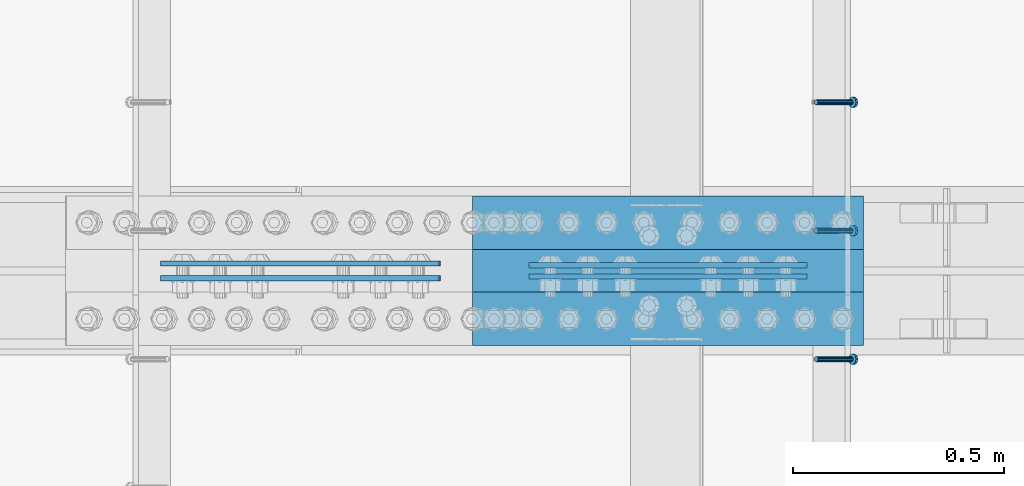
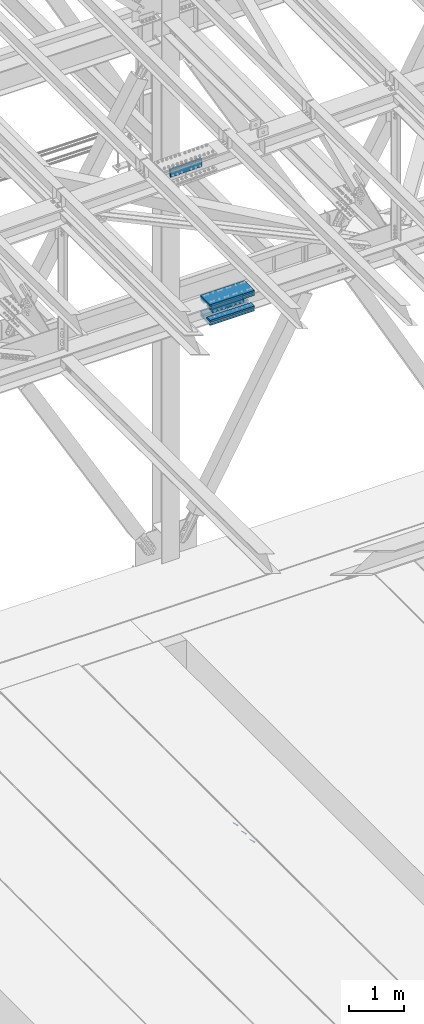
# One storey, part 2485 of 3843: 10 beams, 3 members, 4 elements without a shape of their own.
"""IFC2X3 building model written with IfcOpenShell, lengths in millimetres."""

from ifc_helpers import new_model, si_unit, frame, origin_with_axes, place, context, subcontext, project, spatial, faceted_brep, material, type_object, element, aggregate, save


model = new_model("IFC2X3")

# Units and contexts
model_context = context("Model", 3, precision=1e-05, world=origin_with_axes())
body_context = subcontext(model_context, "Body", "Model", "MODEL_VIEW")
ifc_project = project(units=[si_unit("LENGTHUNIT", "METRE", prefix="MILLI"), si_unit("AREAUNIT", "SQUARE_METRE"), si_unit("VOLUMEUNIT", "CUBIC_METRE"), si_unit("MASSUNIT", "GRAM", prefix="KILO"), si_unit("TIMEUNIT", "SECOND"), si_unit("PLANEANGLEUNIT", "RADIAN"), si_unit("SOLIDANGLEUNIT", "STERADIAN"), si_unit("THERMODYNAMICTEMPERATUREUNIT", "DEGREE_CELSIUS"), si_unit("LUMINOUSINTENSITYUNIT", "LUMEN")], contexts=[model_context])

# Site, building, storey
site_placement = place(None, origin_with_axes())
site = spatial("IfcSite", under=ifc_project, at=site_placement, CompositionType="ELEMENT")
building_placement = place(site_placement, origin_with_axes())
building = spatial("IfcBuilding", under=site, at=building_placement, Name="Undefined", CompositionType="ELEMENT")
storey_placement = place(building_placement, origin_with_axes())
storey = spatial("IfcBuildingStorey", under=building, at=storey_placement, Name="Undefined", CompositionType="ELEMENT", Elevation=0.0)

# Assembly, member
assembly_1_placement = place(storey_placement, origin_with_axes())
assembly_1 = element("IfcElementAssembly", 1, at=assembly_1_placement, inside=storey, Name="EMBED_ANGLE", AssemblyPlace="NOTDEFINED", PredefinedType="RIGID_FRAME")
ifc_material_1 = material(Name="STEEL/A108")
member_type = type_object("IfcMemberType", PredefinedType="NOTDEFINED")
member_1_placement = place(assembly_1_placement, frame((52815.2995, 83775.4227092285, 30446.6625), z_axis=(0.0, 1.0, 0.0), x_axis=(0.707106781186548, 0.0, -0.707106781186548)))
member_1 = element("IfcMember", 2, at=member_1_placement, type_object=member_type, material=ifc_material_1, Name="HEADED STUD ANCHOR", context=body_context, shape_type="Brep", body=[
    faceted_brep([(7.27595761418343e-12, -3.18000006675175, 5.5), (0.0, -5.49999999998363, 3.1800000667572), (118.110000000976, -5.49999999999091, 3.1800000667572), (118.110000000983, -3.18000006675175, 5.5), (0.0, -6.3499999046162, 0.0), (118.110000000968, -6.34999990461256, 0.0), (0.0, -5.49999999998363, -3.1800000667572), (118.110000000976, -5.49999999999091, -3.1800000667572), (7.27595761418343e-12, -3.18000006675175, -5.5), (118.110000000983, -3.18000006675175, -5.5), (7.27595761418343e-12, -1.81898940354586e-12, -6.34999990463257), (118.110000000968, -1.81898940354586e-12, -6.34999990463257), (0.0, 3.18000006675175, -5.5), (118.110000000968, 3.18000006674811, -5.5), (7.27595761418343e-12, 5.49999999998363, -3.1800000667572), (118.110000000983, 5.49999999998363, -3.1800000667572), (7.27595761418343e-12, 6.3499999046162, 0.0), (118.110000000976, 6.34999990461256, 0.0), (7.27595761418343e-12, 5.49999999998363, 3.1800000667572), (118.110000000983, 5.49999999998363, 3.1800000667572), (0.0, 3.18000006675175, 5.5), (118.110000000968, 3.18000006674811, 5.5), (7.27595761418343e-12, -1.81898940354586e-12, 6.34999990463257), (118.110000000968, -1.81898940354586e-12, 6.34999990463257), (120.650000000991, -10.9899997710909, 6.34999990463257), (120.650000000998, -6.34000015257152, 10.9899997711182), (120.650000000991, -12.6999998092379, 0.0), (120.650000000991, -10.9899997710909, -6.34999990463257), (120.650000000998, -6.34000015257152, -10.9899997711182), (120.650000000991, -1.81898940354586e-12, -12.6899995803833), (120.650000000991, 6.34000015257152, -10.9899997711182), (120.650000000998, 10.9899997710909, -6.34999990463257), (120.650000000991, 12.6999998092342, 0.0), (120.650000000998, 10.9899997710909, 6.34999990463257), (120.650000000991, 6.34000015257152, 10.9899997711182), (120.650000000991, -1.81898940354586e-12, 12.6899995803833), (127.000000001048, -10.9899997710945, 6.34999990463257), (127.000000001048, -6.34000015257152, 10.9899997711182), (127.000000001048, -12.6999998092342, 0.0), (127.000000001048, -10.9899997710945, -6.34999990463257), (127.000000001048, -6.34000015257152, -10.9899997711182), (127.000000001048, 1.81898940354586e-12, -12.6899995803833), (127.000000001048, 6.34000015256788, -10.9899997711182), (127.000000001048, 10.9899997710909, -6.34999990463257), (127.000000001048, 12.6999998092379, 0.0), (127.000000001048, 10.9899997710909, 6.34999990463257), (127.000000001048, 6.34000015256788, 10.9899997711182), (127.000000001048, 1.81898940354586e-12, 12.6899995803833)], [[[0, 1, 2, 3]], [[1, 4, 5, 2]], [[4, 6, 7, 5]], [[6, 8, 9, 7]], [[8, 10, 11, 9]], [[10, 12, 13, 11]], [[12, 14, 15, 13]], [[14, 16, 17, 15]], [[16, 18, 19, 17]], [[18, 20, 21, 19]], [[20, 22, 23, 21]], [[22, 0, 3, 23]], [[22, 20, 18, 16, 14, 12, 10, 8, 6, 4, 1, 0]], [[3, 2, 24, 25]], [[2, 5, 26, 24]], [[5, 7, 27, 26]], [[7, 9, 28, 27]], [[9, 11, 29, 28]], [[11, 13, 30, 29]], [[13, 15, 31, 30]], [[15, 17, 32, 31]], [[17, 19, 33, 32]], [[19, 21, 34, 33]], [[21, 23, 35, 34]], [[23, 3, 25, 35]], [[25, 24, 36, 37]], [[24, 26, 38, 36]], [[26, 27, 39, 38]], [[27, 28, 40, 39]], [[28, 29, 41, 40]], [[29, 30, 42, 41]], [[30, 31, 43, 42]], [[31, 32, 44, 43]], [[32, 33, 45, 44]], [[33, 34, 46, 45]], [[34, 35, 47, 46]], [[35, 25, 37, 47]], [[38, 39, 40, 41, 42, 43, 44, 45, 46, 47, 37, 36]]]),
])
aggregate(assembly_1, [member_1])

# Assembly, members
assembly_2_placement = place(storey_placement, origin_with_axes())
assembly_2 = element("IfcElementAssembly", 3, at=assembly_2_placement, inside=storey, Name="EMBED_ANGLE", AssemblyPlace="NOTDEFINED", PredefinedType="RIGID_FRAME")
member_2_placement = place(assembly_2_placement, frame((52815.2995, 84080.2227092285, 30446.6625), z_axis=(0.0, 1.0, 0.0), x_axis=(0.707106781186548, 0.0, -0.707106781186548)))
member_2 = element("IfcMember", 4, at=member_2_placement, type_object=member_type, material=ifc_material_1, Name="HEADED STUD ANCHOR", context=body_context, shape_type="Brep", body=[
    faceted_brep([(7.27595761418343e-12, -3.18000006675175, 5.5), (0.0, -5.49999999998363, 3.1800000667572), (118.110000000976, -5.49999999999091, 3.1800000667572), (118.110000000983, -3.18000006675175, 5.5), (0.0, -6.3499999046162, 0.0), (118.110000000968, -6.34999990461256, 0.0), (0.0, -5.49999999998363, -3.1800000667572), (118.110000000976, -5.49999999999091, -3.1800000667572), (7.27595761418343e-12, -3.18000006675175, -5.5), (118.110000000983, -3.18000006675175, -5.5), (7.27595761418343e-12, -1.81898940354586e-12, -6.34999990463257), (118.110000000968, -1.81898940354586e-12, -6.34999990463257), (0.0, 3.18000006675175, -5.5), (118.110000000968, 3.18000006674811, -5.5), (7.27595761418343e-12, 5.49999999998363, -3.1800000667572), (118.110000000983, 5.49999999998363, -3.1800000667572), (7.27595761418343e-12, 6.3499999046162, 0.0), (118.110000000976, 6.34999990461256, 0.0), (7.27595761418343e-12, 5.49999999998363, 3.1800000667572), (118.110000000983, 5.49999999998363, 3.1800000667572), (0.0, 3.18000006675175, 5.5), (118.110000000968, 3.18000006674811, 5.5), (7.27595761418343e-12, -1.81898940354586e-12, 6.34999990463257), (118.110000000968, -1.81898940354586e-12, 6.34999990463257), (120.650000000991, -10.9899997710909, 6.34999990463257), (120.650000000998, -6.34000015257152, 10.9899997711182), (120.650000000991, -12.6999998092379, 0.0), (120.650000000991, -10.9899997710909, -6.34999990463257), (120.650000000998, -6.34000015257152, -10.9899997711182), (120.650000000991, -1.81898940354586e-12, -12.6899995803833), (120.650000000991, 6.34000015257152, -10.9899997711182), (120.650000000998, 10.9899997710909, -6.34999990463257), (120.650000000991, 12.6999998092342, 0.0), (120.650000000998, 10.9899997710909, 6.34999990463257), (120.650000000991, 6.34000015257152, 10.9899997711182), (120.650000000991, -1.81898940354586e-12, 12.6899995803833), (127.000000001048, -10.9899997710945, 6.34999990463257), (127.000000001048, -6.34000015257152, 10.9899997711182), (127.000000001048, -12.6999998092342, 0.0), (127.000000001048, -10.9899997710945, -6.34999990463257), (127.000000001048, -6.34000015257152, -10.9899997711182), (127.000000001048, 1.81898940354586e-12, -12.6899995803833), (127.000000001048, 6.34000015256788, -10.9899997711182), (127.000000001048, 10.9899997710909, -6.34999990463257), (127.000000001048, 12.6999998092379, 0.0), (127.000000001048, 10.9899997710909, 6.34999990463257), (127.000000001048, 6.34000015256788, 10.9899997711182), (127.000000001048, 1.81898940354586e-12, 12.6899995803833)], [[[0, 1, 2, 3]], [[1, 4, 5, 2]], [[4, 6, 7, 5]], [[6, 8, 9, 7]], [[8, 10, 11, 9]], [[10, 12, 13, 11]], [[12, 14, 15, 13]], [[14, 16, 17, 15]], [[16, 18, 19, 17]], [[18, 20, 21, 19]], [[20, 22, 23, 21]], [[22, 0, 3, 23]], [[22, 20, 18, 16, 14, 12, 10, 8, 6, 4, 1, 0]], [[3, 2, 24, 25]], [[2, 5, 26, 24]], [[5, 7, 27, 26]], [[7, 9, 28, 27]], [[9, 11, 29, 28]], [[11, 13, 30, 29]], [[13, 15, 31, 30]], [[15, 17, 32, 31]], [[17, 19, 33, 32]], [[19, 21, 34, 33]], [[21, 23, 35, 34]], [[23, 3, 25, 35]], [[25, 24, 36, 37]], [[24, 26, 38, 36]], [[26, 27, 39, 38]], [[27, 28, 40, 39]], [[28, 29, 41, 40]], [[29, 30, 42, 41]], [[30, 31, 43, 42]], [[31, 32, 44, 43]], [[32, 33, 45, 44]], [[33, 34, 46, 45]], [[34, 35, 47, 46]], [[35, 25, 37, 47]], [[38, 39, 40, 41, 42, 43, 44, 45, 46, 47, 37, 36]]]),
])
member_3_placement = place(assembly_2_placement, frame((52815.2995, 84385.0227092285, 30446.6625), z_axis=(0.0, 1.0, 0.0), x_axis=(0.707106781186548, 0.0, -0.707106781186548)))
member_3 = element("IfcMember", 5, at=member_3_placement, type_object=member_type, material=ifc_material_1, Name="HEADED STUD ANCHOR", context=body_context, shape_type="Brep", body=[
    faceted_brep([(7.27595761418343e-12, -3.18000006675175, 5.5), (0.0, -5.49999999998363, 3.1800000667572), (118.110000000976, -5.49999999999091, 3.1800000667572), (118.110000000983, -3.18000006675175, 5.5), (0.0, -6.3499999046162, 0.0), (118.110000000968, -6.34999990461256, 0.0), (0.0, -5.49999999998363, -3.1800000667572), (118.110000000976, -5.49999999999091, -3.1800000667572), (7.27595761418343e-12, -3.18000006675175, -5.5), (118.110000000983, -3.18000006675175, -5.5), (7.27595761418343e-12, -1.81898940354586e-12, -6.34999990463257), (118.110000000968, -1.81898940354586e-12, -6.34999990463257), (0.0, 3.18000006675175, -5.5), (118.110000000968, 3.18000006674811, -5.5), (7.27595761418343e-12, 5.49999999998363, -3.1800000667572), (118.110000000983, 5.49999999998363, -3.1800000667572), (7.27595761418343e-12, 6.3499999046162, 0.0), (118.110000000976, 6.34999990461256, 0.0), (7.27595761418343e-12, 5.49999999998363, 3.1800000667572), (118.110000000983, 5.49999999998363, 3.1800000667572), (0.0, 3.18000006675175, 5.5), (118.110000000968, 3.18000006674811, 5.5), (7.27595761418343e-12, -1.81898940354586e-12, 6.34999990463257), (118.110000000968, -1.81898940354586e-12, 6.34999990463257), (120.650000000991, -10.9899997710909, 6.34999990463257), (120.650000000998, -6.34000015257152, 10.9899997711182), (120.650000000991, -12.6999998092379, 0.0), (120.650000000991, -10.9899997710909, -6.34999990463257), (120.650000000998, -6.34000015257152, -10.9899997711182), (120.650000000991, -1.81898940354586e-12, -12.6899995803833), (120.650000000991, 6.34000015257152, -10.9899997711182), (120.650000000998, 10.9899997710909, -6.34999990463257), (120.650000000991, 12.6999998092342, 0.0), (120.650000000998, 10.9899997710909, 6.34999990463257), (120.650000000991, 6.34000015257152, 10.9899997711182), (120.650000000991, -1.81898940354586e-12, 12.6899995803833), (127.000000001048, -10.9899997710945, 6.34999990463257), (127.000000001048, -6.34000015257152, 10.9899997711182), (127.000000001048, -12.6999998092342, 0.0), (127.000000001048, -10.9899997710945, -6.34999990463257), (127.000000001048, -6.34000015257152, -10.9899997711182), (127.000000001048, 1.81898940354586e-12, -12.6899995803833), (127.000000001048, 6.34000015256788, -10.9899997711182), (127.000000001048, 10.9899997710909, -6.34999990463257), (127.000000001048, 12.6999998092379, 0.0), (127.000000001048, 10.9899997710909, 6.34999990463257), (127.000000001048, 6.34000015256788, 10.9899997711182), (127.000000001048, 1.81898940354586e-12, 12.6899995803833)], [[[0, 1, 2, 3]], [[1, 4, 5, 2]], [[4, 6, 7, 5]], [[6, 8, 9, 7]], [[8, 10, 11, 9]], [[10, 12, 13, 11]], [[12, 14, 15, 13]], [[14, 16, 17, 15]], [[16, 18, 19, 17]], [[18, 20, 21, 19]], [[20, 22, 23, 21]], [[22, 0, 3, 23]], [[22, 20, 18, 16, 14, 12, 10, 8, 6, 4, 1, 0]], [[3, 2, 24, 25]], [[2, 5, 26, 24]], [[5, 7, 27, 26]], [[7, 9, 28, 27]], [[9, 11, 29, 28]], [[11, 13, 30, 29]], [[13, 15, 31, 30]], [[15, 17, 32, 31]], [[17, 19, 33, 32]], [[19, 21, 34, 33]], [[21, 23, 35, 34]], [[23, 3, 25, 35]], [[25, 24, 36, 37]], [[24, 26, 38, 36]], [[26, 27, 39, 38]], [[27, 28, 40, 39]], [[28, 29, 41, 40]], [[29, 30, 42, 41]], [[30, 31, 43, 42]], [[31, 32, 44, 43]], [[32, 33, 45, 44]], [[33, 34, 46, 45]], [[34, 35, 47, 46]], [[35, 25, 37, 47]], [[38, 39, 40, 41, 42, 43, 44, 45, 46, 47, 37, 36]]]),
])
aggregate(assembly_2, [member_2, member_3])

# Assembly, beams
assembly_3_placement = place(storey_placement, origin_with_axes())
assembly_3 = element("IfcElementAssembly", 6, at=assembly_3_placement, inside=storey, Name="BEAM", AssemblyPlace="NOTDEFINED", PredefinedType="RIGID_FRAME")
ifc_material_2 = material(Name="STEEL/A572-50")
beam_type_1 = type_object("IfcBeamType", PredefinedType="NOTDEFINED")
beam_1_placement = place(assembly_3_placement, frame((52793.8999615172, 83971.60625, 42254.3802462858), z_axis=(-0.00048281500021403, 0.0, 0.999999883444831), x_axis=(-0.999999883445314, 0.0, -0.000482814000210543)))
beam_1 = element("IfcBeam", 7, at=beam_1_placement, type_object=beam_type_1, material=ifc_material_2, Name="PLATE", context=body_context, shape_type="Brep", body=[
    faceted_brep([(1.45519152283669e-11, 6.35000000000582, -88.8999999998996), (0.0, 6.34999999999854, 88.9000015258789), (660.399999982677, 6.35000000000582, 88.8999999999651), (660.399999982707, 6.35000000000582, -88.8999999998268), (0.0, -6.34999999999854, 88.9000015258789), (660.399999982677, -6.35000000000582, 88.8999999999651), (1.45519152283669e-11, -6.35000000000582, -88.8999999998996), (660.399999982707, -6.35000000000582, -88.8999999998268)], [[[0, 1, 2, 3]], [[1, 4, 5, 2]], [[4, 6, 7, 5]], [[6, 0, 3, 7]], [[5, 7, 3, 2]], [[6, 4, 1, 0]]]),
])
beam_2_placement = place(assembly_3_placement, frame((52793.8999615172, 83998.59375, 42254.3802462858), z_axis=(-0.00048281500021403, 0.0, 0.999999883444831), x_axis=(-0.999999883445314, 0.0, -0.000482814000210543)))
beam_2 = element("IfcBeam", 8, at=beam_2_placement, type_object=beam_type_1, material=ifc_material_2, Name="PLATE", context=body_context, shape_type="Brep", body=[
    faceted_brep([(1.45519152283669e-11, 6.35000000000582, -88.8999999998996), (0.0, 6.34999999999854, 88.9000015258789), (660.399999982677, 6.35000000000582, 88.8999999999651), (660.399999982707, 6.35000000000582, -88.8999999998268), (0.0, -6.34999999999854, 88.9000015258789), (660.399999982677, -6.35000000000582, 88.8999999999651), (1.45519152283669e-11, -6.35000000000582, -88.8999999998996), (660.399999982707, -6.35000000000582, -88.8999999998268)], [[[0, 1, 2, 3]], [[1, 4, 5, 2]], [[4, 6, 7, 5]], [[6, 0, 3, 7]], [[5, 7, 3, 2]], [[6, 4, 1, 0]]]),
])

assembly_4_placement = place(storey_placement, origin_with_axes())
assembly_4 = element("IfcElementAssembly", 9, at=assembly_4_placement, inside=storey, Name="BEAM", AssemblyPlace="NOTDEFINED", PredefinedType="RIGID_FRAME")
beam_3_placement = place(assembly_4_placement, frame((51921.7814193097, 83967.6375, 45553.5510765957), z_axis=(-0.0216342480057937, 0.0, 0.999765952267441), x_axis=(-0.999765952267441, 0.0, -0.0216342480057875)))
beam_3 = element("IfcBeam", 10, at=beam_3_placement, type_object=beam_type_1, material=ifc_material_2, Name="PLATE", context=body_context, shape_type="Brep", body=[
    faceted_brep([(1.45519152283669e-11, 6.35000000000582, -88.8999999998996), (0.0, 6.34999999999854, 88.9000015258789), (660.399999982677, 6.35000000000582, 88.8999999999651), (660.399999982707, 6.35000000000582, -88.8999999998268), (0.0, -6.34999999999854, 88.9000015258789), (660.399999982677, -6.35000000000582, 88.8999999999651), (1.45519152283669e-11, -6.35000000000582, -88.8999999998996), (660.399999982707, -6.35000000000582, -88.8999999998268)], [[[0, 1, 2, 3]], [[1, 4, 5, 2]], [[4, 6, 7, 5]], [[6, 0, 3, 7]], [[5, 7, 3, 2]], [[6, 4, 1, 0]]]),
])
beam_4_placement = place(assembly_4_placement, frame((51921.7814193097, 84002.5625, 45553.5510765957), z_axis=(-0.0216342480057937, 0.0, 0.999765952267441), x_axis=(-0.999765952267441, 0.0, -0.0216342480057875)))
beam_4 = element("IfcBeam", 11, at=beam_4_placement, type_object=beam_type_1, material=ifc_material_2, Name="PLATE", context=body_context, shape_type="Brep", body=[
    faceted_brep([(1.45519152283669e-11, 6.35000000000582, -88.8999999998996), (0.0, 6.34999999999854, 88.9000015258789), (660.399999982677, 6.35000000000582, 88.8999999999651), (660.399999982707, 6.35000000000582, -88.8999999998268), (0.0, -6.34999999999854, 88.9000015258789), (660.399999982677, -6.35000000000582, 88.8999999999651), (1.45519152283669e-11, -6.35000000000582, -88.8999999998996), (660.399999982707, -6.35000000000582, -88.8999999998268)], [[[0, 1, 2, 3]], [[1, 4, 5, 2]], [[4, 6, 7, 5]], [[6, 0, 3, 7]], [[5, 7, 3, 2]], [[6, 4, 1, 0]]]),
])
aggregate(assembly_4, [beam_3, beam_4])

# Beam
beam_type_2 = type_object("IfcBeamType", PredefinedType="NOTDEFINED")
beam_5_placement = place(assembly_3_placement, frame((52927.3495869212, 83985.1, 42048.0696536767), z_axis=(0.0, 1.0, 0.0), x_axis=(-0.999999883445314, 0.0, -0.000482814000210543)))
beam_5 = element("IfcBeam", 12, at=beam_5_placement, type_object=beam_type_2, material=ifc_material_2, Name="PLATE", context=body_context, shape_type="Brep", body=[
    faceted_brep([(0.0, 22.2249999999767, -177.800000000003), (0.0, 22.2249999999767, 177.800000000003), (927.099999958984, 22.2250000000859, 177.800000000003), (927.099999958984, 22.2250000000859, -177.800000000003), (0.0, -22.2249999999694, 177.800000000003), (927.099999958984, -22.2249999998749, 177.800000000003), (0.0, -22.2249999999694, -177.800000000003), (927.099999958984, -22.2249999998749, -177.800000000003)], [[[0, 1, 2, 3]], [[1, 4, 5, 2]], [[4, 6, 7, 5]], [[6, 0, 3, 7]], [[5, 7, 3, 2]], [[6, 4, 1, 0]]]),
])

beam_6_placement = place(assembly_3_placement, frame((52927.1503050309, 83985.1, 42460.8196056144), z_axis=(0.0, 1.0, 0.0), x_axis=(-0.999999883445314, 0.0, -0.000482814000210543)))
beam_6 = element("IfcBeam", 13, at=beam_6_placement, type_object=beam_type_2, material=ifc_material_2, Name="PLATE", context=body_context, shape_type="Brep", body=[
    faceted_brep([(0.0, 22.2249999999767, -177.800000000003), (0.0, 22.2249999999767, 177.800000000003), (927.099999958984, 22.2250000000859, 177.800000000003), (927.099999958984, 22.2250000000859, -177.800000000003), (0.0, -22.2249999999694, 177.800000000003), (927.099999958984, -22.2249999998749, 177.800000000003), (0.0, -22.2249999999694, -177.800000000003), (927.099999958984, -22.2249999998749, -177.800000000003)], [[[0, 1, 2, 3]], [[1, 4, 5, 2]], [[4, 6, 7, 5]], [[6, 0, 3, 7]], [[5, 7, 3, 2]], [[6, 4, 1, 0]]]),
])

beam_type_3 = type_object("IfcBeamType", PredefinedType="NOTDEFINED")
beam_7_placement = place(assembly_3_placement, frame((52000.2167368103, 83870.8, 42115.8845279769), z_axis=(0.0, 1.0, 0.0), x_axis=(0.999999883444831, 0.0, 0.000482815000217081)))
beam_7 = element("IfcBeam", 14, at=beam_7_placement, type_object=beam_type_3, material=ifc_material_2, Name="PLATE", context=body_context, shape_type="Brep", body=[
    faceted_brep([(-7.27595761418343e-11, 22.2250000000786, -63.5), (-7.27595761418343e-11, 22.2250000000786, 63.5), (927.099999951592, 22.2250000031054, 63.5), (927.099999951592, 22.2250000031054, -63.5), (6.54836185276508e-11, -22.2250000000713, 63.5), (927.099999951744, -22.2249999970372, 63.5), (6.54836185276508e-11, -22.2250000000713, -63.5), (927.099999951744, -22.2249999970372, -63.5)], [[[0, 1, 2, 3]], [[1, 4, 5, 2]], [[4, 6, 7, 5]], [[6, 0, 3, 7]], [[5, 7, 3, 2]], [[6, 4, 1, 0]]]),
])

beam_8_placement = place(assembly_3_placement, frame((52000.0833712376, 83870.8, 42392.1094957455), z_axis=(0.0, 1.0, 0.0), x_axis=(0.999999883444831, 0.0, 0.000482815000217081)))
beam_8 = element("IfcBeam", 15, at=beam_8_placement, type_object=beam_type_3, material=ifc_material_2, Name="PLATE", context=body_context, shape_type="Brep", body=[
    faceted_brep([(-7.27595761418343e-11, 22.2250000000786, -63.5), (-7.27595761418343e-11, 22.2250000000786, 63.5), (927.099999951592, 22.2250000031054, 63.5), (927.099999951592, 22.2250000031054, -63.5), (6.54836185276508e-11, -22.2250000000713, 63.5), (927.099999951744, -22.2249999970372, 63.5), (6.54836185276508e-11, -22.2250000000713, -63.5), (927.099999951744, -22.2249999970372, -63.5)], [[[0, 1, 2, 3]], [[1, 4, 5, 2]], [[4, 6, 7, 5]], [[6, 0, 3, 7]], [[5, 7, 3, 2]], [[6, 4, 1, 0]]]),
])

beam_9_placement = place(assembly_3_placement, frame((52000.2167368103, 84099.4, 42115.8845279769), z_axis=(0.0, 1.0, 0.0), x_axis=(0.999999883444831, 0.0, 0.000482815000217081)))
beam_9 = element("IfcBeam", 16, at=beam_9_placement, type_object=beam_type_3, material=ifc_material_2, Name="PLATE", context=body_context, shape_type="Brep", body=[
    faceted_brep([(-7.27595761418343e-11, 22.2250000000786, -63.5), (-7.27595761418343e-11, 22.2250000000786, 63.5), (927.099999951592, 22.2250000031054, 63.5), (927.099999951592, 22.2250000031054, -63.5), (6.54836185276508e-11, -22.2250000000713, 63.5), (927.099999951744, -22.2249999970372, 63.5), (6.54836185276508e-11, -22.2250000000713, -63.5), (927.099999951744, -22.2249999970372, -63.5)], [[[0, 1, 2, 3]], [[1, 4, 5, 2]], [[4, 6, 7, 5]], [[6, 0, 3, 7]], [[5, 7, 3, 2]], [[6, 4, 1, 0]]]),
])

beam_10_placement = place(assembly_3_placement, frame((52000.0833712376, 84099.4, 42392.1094957455), z_axis=(0.0, 1.0, 0.0), x_axis=(0.999999883444831, 0.0, 0.000482815000217081)))
beam_10 = element("IfcBeam", 17, at=beam_10_placement, type_object=beam_type_3, material=ifc_material_2, Name="PLATE", context=body_context, shape_type="Brep", body=[
    faceted_brep([(-7.27595761418343e-11, 22.2250000000786, -63.5), (-7.27595761418343e-11, 22.2250000000786, 63.5), (927.099999951592, 22.2250000031054, 63.5), (927.099999951592, 22.2250000031054, -63.5), (6.54836185276508e-11, -22.2250000000713, 63.5), (927.099999951744, -22.2249999970372, 63.5), (6.54836185276508e-11, -22.2250000000713, -63.5), (927.099999951744, -22.2249999970372, -63.5)], [[[0, 1, 2, 3]], [[1, 4, 5, 2]], [[4, 6, 7, 5]], [[6, 0, 3, 7]], [[5, 7, 3, 2]], [[6, 4, 1, 0]]]),
])

aggregate(assembly_3, [beam_1, beam_2, beam_7, beam_8, beam_9, beam_10, beam_5, beam_6])

save(model, "model.ifc")
